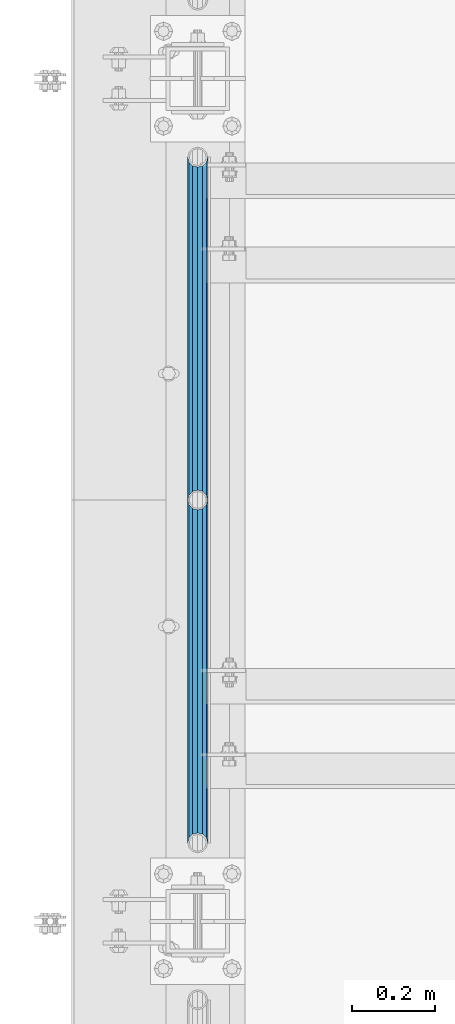
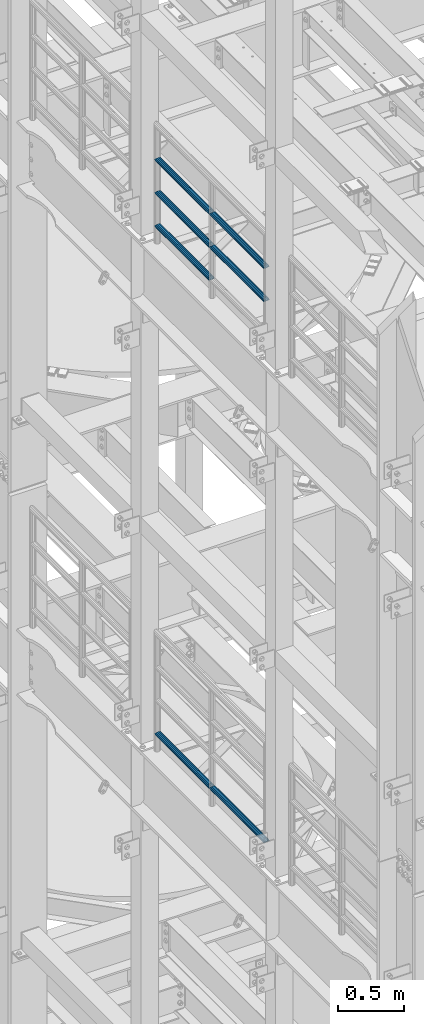
# One storey, part 1251 of 1876: 7 beams, 2 elements without a shape of their own.
"""IFC2X3 building model written with IfcOpenShell, lengths in millimetres."""

from ifc_helpers import new_model, si_unit, frame, origin_with_axes, place, context, subcontext, project, spatial, faceted_brep, material, type_object, element, aggregate, save


model = new_model("IFC2X3")

# Units and contexts
model_context = context("Model", 3, precision=1e-05, world=origin_with_axes())
body_context = subcontext(model_context, "Body", "Model", "MODEL_VIEW")
ifc_project = project(units=[si_unit("LENGTHUNIT", "METRE", prefix="MILLI"), si_unit("AREAUNIT", "SQUARE_METRE"), si_unit("VOLUMEUNIT", "CUBIC_METRE"), si_unit("MASSUNIT", "GRAM", prefix="KILO"), si_unit("TIMEUNIT", "SECOND"), si_unit("PLANEANGLEUNIT", "RADIAN"), si_unit("SOLIDANGLEUNIT", "STERADIAN"), si_unit("THERMODYNAMICTEMPERATUREUNIT", "DEGREE_CELSIUS"), si_unit("LUMINOUSINTENSITYUNIT", "LUMEN")], contexts=[model_context])

# Site, building, storey
site_placement = place(None, origin_with_axes())
site = spatial("IfcSite", under=ifc_project, at=site_placement, CompositionType="ELEMENT")
building_placement = place(site_placement, origin_with_axes())
building = spatial("IfcBuilding", under=site, at=building_placement, Name="Undefined", CompositionType="ELEMENT")
storey_placement = place(building_placement, origin_with_axes())
storey = spatial("IfcBuildingStorey", under=building, at=storey_placement, Name="Undefined", CompositionType="ELEMENT", Elevation=0.0)

# Assembly, beams
assembly_1_placement = place(storey_placement, origin_with_axes())
assembly_1 = element("IfcElementAssembly", 1, at=assembly_1_placement, inside=storey, Name="RAIL", AssemblyPlace="NOTDEFINED", PredefinedType="RIGID_FRAME")
ifc_material = material()
beam_type = type_object("IfcBeamType", Name="PIPE1-1/2SCH40", PredefinedType="NOTDEFINED")
beam_1_placement = place(assembly_1_placement, frame((-1.81898940354586e-12, 5398.77, 18145.125), z_axis=(0.0, 0.0, 1.0), x_axis=(0.0, -1.0, 0.0)))
beam_1 = element("IfcBeam", 2, at=beam_1_placement, type_object=beam_type, material=ifc_material, Name="RAIL", ObjectType="PIPE1-1/2SCH40", context=body_context, shape_type="Brep", body=[
    faceted_brep([(805.872807006681, -12.0649999999996, 20.8971929933177), (805.872807006683, -12.0649999999996, 15.8661214311796), (805.379378568819, -10.2235000000001, 17.7076214311819), (802.640000000001, 0.0, 20.4470000000001), (802.640000000001, 0.0, 24.130000000001), (805.379378568819, 10.2235000000001, 17.7076214311819), (805.872807006683, 12.0649999999996, 15.8661214311796), (805.872807006681, 12.0649999999996, 20.8971929933177), (826.77, 24.1300000000001, 0.0), (814.705, 20.8971929933186, 12.0649999999987), (814.705, 20.8971929933186, -12.0649999999987), (811.515428437862, 17.7076214311801, 10.2235000000001), (814.254807006682, 20.4470000000001, 0.0), (811.515428437862, 17.7076214311801, -10.2235000000001), (805.872807006683, 12.0649999999996, -15.8661214311796), (805.872807006681, 12.0649999999996, -20.8971929933177), (805.379378568819, 10.2235000000001, -17.7076214311819), (802.640000000001, 0.0, -20.4470000000001), (802.640000000001, 0.0, -24.130000000001), (805.872807006683, -12.0649999999996, -15.8661214311796), (805.872807006681, -12.0649999999996, -20.8971929933177), (805.379378568819, -10.2235000000001, -17.7076214311819), (826.77, -24.1300000000001, 0.0), (814.705, -20.8971929933186, -12.0649999999987), (814.705, -20.8971929933186, 12.0649999999987), (811.515428437862, -17.7076214311801, -10.2235000000001), (814.254807006682, -20.4470000000001, 0.0), (811.515428437862, -17.7076214311801, 10.2235000000001), (12.0650000000064, -20.8971929933177, -12.0649999999987), (20.8971929933249, -12.0650000000005, -20.8971929933177), (0.0, 24.1299999999992, 0.0), (12.0650000000064, 20.8971929933177, -12.0649999999987), (12.0650000000064, 20.8971929933177, 12.0649999999987), (20.8971929933249, 12.0650000000005, 20.8971929933177), (24.1300000000064, 0.0, 24.130000000001), (20.8971929933249, 12.0650000000005, -20.8971929933177), (24.1300000000063, 0.0, -24.130000000001), (24.1300000000063, 0.0, -20.4470000000001), (20.8971929933249, -12.0650000000005, -15.8661214311796), (21.3906214311868, -10.2235000000001, -17.7076214311819), (21.3906214311868, 10.2235000000001, -17.7076214311819), (20.8971929933249, 12.0650000000005, -15.8661214311796), (15.2545715621445, 17.7076214311801, -10.2235000000001), (12.5151929933249, 20.4470000000001, 0.0), (15.2545715621445, 17.7076214311801, 10.2235000000001), (20.8971929933249, 12.0650000000005, 15.8661214311796), (21.3906214311868, 10.2235000000001, 17.7076214311819), (24.1300000000064, 0.0, 20.4470000000001), (21.3906214311868, -10.2235000000001, 17.7076214311819), (20.8971929933249, -12.0650000000005, 15.8661214311796), (20.8971929933249, -12.0650000000005, 20.8971929933177), (12.0650000000064, -20.8971929933177, 12.0649999999987), (0.0, -24.1299999999992, 0.0), (15.2545715621445, -17.7076214311801, 10.2235000000001), (12.5151929933249, -20.4470000000001, 0.0), (15.2545715621445, -17.7076214311801, -10.2235000000001)], [[[0, 1, 2, 3, 4]], [[4, 3, 5, 6, 7]], [[8, 9, 10]], [[7, 6, 11, 12, 13, 14, 15, 10, 9]], [[16, 17, 18, 15, 14]], [[19, 20, 18, 17, 21]], [[22, 23, 24]], [[24, 23, 20, 19, 25, 26, 27, 1, 0]], [[28, 29, 20, 23]], [[30, 31, 32]], [[33, 34, 4, 7]], [[32, 33, 7, 9]], [[30, 32, 9, 8]], [[31, 30, 8, 10]], [[35, 31, 10, 15]], [[36, 35, 15, 18]], [[29, 36, 18, 20]], [[37, 36, 29, 38, 39]], [[40, 41, 35, 36, 37]], [[32, 31, 35, 41, 42, 43, 44, 45, 33]], [[33, 45, 46, 47, 34]], [[34, 47, 48, 49, 50]], [[34, 50, 0, 4]], [[50, 51, 24, 0]], [[51, 52, 22, 24]], [[52, 28, 23, 22]], [[51, 28, 52]], [[50, 49, 53, 54, 55, 38, 29, 28, 51]], [[55, 54, 26, 25]], [[21, 39, 38, 55, 25, 19]], [[37, 39, 21, 17]], [[40, 37, 17, 16]], [[42, 41, 40, 16, 14, 13]], [[43, 42, 13, 12]], [[44, 43, 12, 11]], [[5, 46, 45, 44, 11, 6]], [[47, 46, 5, 3]], [[48, 47, 3, 2]], [[53, 49, 48, 2, 1, 27]], [[54, 53, 27, 26]]]),
])
beam_2_placement = place(assembly_1_placement, frame((-1.81898940354586e-12, 3745.23, 18449.925), z_axis=(0.0, 0.0, -1.0), x_axis=(0.0, 1.0, 0.0)))
beam_2 = element("IfcBeam", 3, at=beam_2_placement, type_object=beam_type, material=ifc_material, Name="RAIL", ObjectType="PIPE1-1/2SCH40", context=body_context, shape_type="Brep", body=[
    faceted_brep([(0.0, 24.1299999999992, 0.0), (12.0650000000064, 20.8971929933177, -12.0649999999987), (12.0650000000064, 20.8971929933177, 12.0649999999987), (12.0650000000064, -20.8971929933177, 12.0649999999987), (12.0650000000064, -20.8971929933177, -12.0649999999987), (0.0, -24.1299999999992, 0.0), (20.8971929933249, -12.0650000000005, 20.8971929933177), (20.8971929933249, -12.0650000000005, 15.8661214311796), (15.2545715621445, -17.7076214311801, 10.2235000000001), (12.5151929933249, -20.4470000000001, 0.0), (15.2545715621445, -17.7076214311801, -10.2235000000001), (20.8971929933249, -12.0650000000005, -15.8661214311796), (20.8971929933249, -12.0650000000005, -20.8971929933177), (24.1300000000063, 0.0, -20.4470000000001), (24.1300000000063, 0.0, -24.130000000001), (21.3906214311868, -10.2235000000001, -17.7076214311819), (21.3906214311868, 10.2235000000001, -17.7076214311819), (20.8971929933249, 12.0650000000005, -15.8661214311796), (20.8971929933249, 12.0650000000005, -20.8971929933177), (15.2545715621445, 17.7076214311801, -10.2235000000001), (12.5151929933249, 20.4470000000001, 0.0), (15.2545715621445, 17.7076214311801, 10.2235000000001), (20.8971929933249, 12.0650000000005, 15.8661214311796), (20.8971929933249, 12.0650000000005, 20.8971929933177), (21.3906214311868, 10.2235000000001, 17.7076214311819), (24.1300000000064, 0.0, 20.4470000000001), (24.1300000000064, 0.0, 24.130000000001), (21.3906214311868, -10.2235000000001, 17.7076214311819), (826.77, 24.1300000000001, 0.0), (814.705, 20.8971929933186, -12.0649999999987), (805.872807006681, 12.0649999999996, -20.8971929933177), (826.77, -24.1300000000001, 0.0), (814.705, -20.8971929933186, -12.0649999999987), (814.705, -20.8971929933186, 12.0649999999987), (805.872807006681, -12.0649999999996, 20.8971929933177), (805.872807006681, -12.0649999999996, -20.8971929933177), (802.640000000001, 0.0, -24.130000000001), (805.379378568819, 10.2235000000001, -17.7076214311819), (802.640000000001, 0.0, -20.4470000000001), (805.872807006683, 12.0649999999996, -15.8661214311796), (805.872807006683, -12.0649999999996, -15.8661214311796), (805.379378568819, -10.2235000000001, -17.7076214311819), (811.515428437862, -17.7076214311801, -10.2235000000001), (814.254807006682, -20.4470000000001, 0.0), (811.515428437862, -17.7076214311801, 10.2235000000001), (805.872807006683, -12.0649999999996, 15.8661214311796), (805.379378568819, -10.2235000000001, 17.7076214311819), (802.640000000001, 0.0, 20.4470000000001), (802.640000000001, 0.0, 24.130000000001), (805.872807006681, 12.0649999999996, 20.8971929933177), (814.705, 20.8971929933186, 12.0649999999987), (805.872807006683, 12.0649999999996, 15.8661214311796), (811.515428437862, 17.7076214311801, 10.2235000000001), (814.254807006682, 20.4470000000001, 0.0), (811.515428437862, 17.7076214311801, -10.2235000000001), (805.379378568819, 10.2235000000001, 17.7076214311819)], [[[0, 1, 2]], [[3, 4, 5]], [[6, 7, 8, 9, 10, 11, 12, 4, 3]], [[13, 14, 12, 11, 15]], [[16, 17, 18, 14, 13]], [[2, 1, 18, 17, 19, 20, 21, 22, 23]], [[23, 22, 24, 25, 26]], [[26, 25, 27, 7, 6]], [[1, 0, 28, 29]], [[18, 1, 29, 30]], [[31, 32, 33]], [[6, 3, 33, 34]], [[3, 5, 31, 33]], [[5, 4, 32, 31]], [[4, 12, 35, 32]], [[12, 14, 36, 35]], [[14, 18, 30, 36]], [[37, 38, 36, 30, 39]], [[40, 35, 36, 38, 41]], [[33, 32, 35, 40, 42, 43, 44, 45, 34]], [[34, 45, 46, 47, 48]], [[26, 6, 34, 48]], [[2, 23, 49, 50]], [[23, 26, 48, 49]], [[0, 2, 50, 28]], [[28, 50, 29]], [[49, 51, 52, 53, 54, 39, 30, 29, 50]], [[48, 47, 55, 51, 49]], [[25, 24, 55, 47]], [[55, 24, 22, 21, 52, 51]], [[21, 20, 53, 52]], [[20, 19, 54, 53]], [[19, 17, 16, 37, 39, 54]], [[16, 13, 38, 37]], [[13, 15, 41, 38]], [[41, 15, 11, 10, 42, 40]], [[10, 9, 43, 42]], [[9, 8, 44, 43]], [[8, 7, 27, 46, 45, 44]], [[27, 25, 47, 46]]]),
])
beam_3_placement = place(assembly_1_placement, frame((-1.81898940354586e-12, 4572.0, 18449.925), z_axis=(0.0, 0.0, -1.0), x_axis=(0.0, 1.0, 0.0)))
beam_3 = element("IfcBeam", 4, at=beam_3_placement, type_object=beam_type, material=ifc_material, Name="RAIL", ObjectType="PIPE1-1/2SCH40", context=body_context, shape_type="Brep", body=[
    faceted_brep([(0.0, 24.1299999999992, 0.0), (12.0650000000064, 20.8971929933177, -12.0649999999987), (12.0650000000064, 20.8971929933177, 12.0649999999987), (12.0650000000064, -20.8971929933177, 12.0649999999987), (12.0650000000064, -20.8971929933177, -12.0649999999987), (0.0, -24.1299999999992, 0.0), (20.8971929933249, -12.0650000000005, 20.8971929933177), (20.8971929933249, -12.0650000000005, 15.8661214311796), (15.2545715621445, -17.7076214311801, 10.2235000000001), (12.5151929933249, -20.4470000000001, 0.0), (15.2545715621445, -17.7076214311801, -10.2235000000001), (20.8971929933249, -12.0650000000005, -15.8661214311796), (20.8971929933249, -12.0650000000005, -20.8971929933177), (24.1300000000063, 0.0, -20.4470000000001), (24.1300000000063, 0.0, -24.130000000001), (21.3906214311868, -10.2235000000001, -17.7076214311819), (21.3906214311868, 10.2235000000001, -17.7076214311819), (20.8971929933249, 12.0650000000005, -15.8661214311796), (20.8971929933249, 12.0650000000005, -20.8971929933177), (15.2545715621445, 17.7076214311801, -10.2235000000001), (12.5151929933249, 20.4470000000001, 0.0), (15.2545715621445, 17.7076214311801, 10.2235000000001), (20.8971929933249, 12.0650000000005, 15.8661214311796), (20.8971929933249, 12.0650000000005, 20.8971929933177), (21.3906214311868, 10.2235000000001, 17.7076214311819), (24.1300000000064, 0.0, 20.4470000000001), (24.1300000000064, 0.0, 24.130000000001), (21.3906214311868, -10.2235000000001, 17.7076214311819), (826.77, 24.1300000000001, 0.0), (814.705, 20.8971929933186, -12.0649999999987), (805.872807006681, 12.0649999999996, -20.8971929933177), (826.77, -24.1300000000001, 0.0), (814.705, -20.8971929933186, -12.0649999999987), (814.705, -20.8971929933186, 12.0649999999987), (805.872807006681, -12.0649999999996, 20.8971929933177), (805.872807006681, -12.0649999999996, -20.8971929933177), (802.640000000001, 0.0, -24.130000000001), (805.379378568819, 10.2235000000001, -17.7076214311819), (802.640000000001, 0.0, -20.4470000000001), (805.872807006683, 12.0649999999996, -15.8661214311796), (805.872807006683, -12.0649999999996, -15.8661214311796), (805.379378568819, -10.2235000000001, -17.7076214311819), (811.515428437862, -17.7076214311801, -10.2235000000001), (814.254807006682, -20.4470000000001, 0.0), (811.515428437862, -17.7076214311801, 10.2235000000001), (805.872807006683, -12.0649999999996, 15.8661214311796), (805.379378568819, -10.2235000000001, 17.7076214311819), (802.640000000001, 0.0, 20.4470000000001), (802.640000000001, 0.0, 24.130000000001), (805.872807006681, 12.0649999999996, 20.8971929933177), (814.705, 20.8971929933186, 12.0649999999987), (805.872807006683, 12.0649999999996, 15.8661214311796), (811.515428437862, 17.7076214311801, 10.2235000000001), (814.254807006682, 20.4470000000001, 0.0), (811.515428437862, 17.7076214311801, -10.2235000000001), (805.379378568819, 10.2235000000001, 17.7076214311819)], [[[0, 1, 2]], [[3, 4, 5]], [[6, 7, 8, 9, 10, 11, 12, 4, 3]], [[13, 14, 12, 11, 15]], [[16, 17, 18, 14, 13]], [[2, 1, 18, 17, 19, 20, 21, 22, 23]], [[23, 22, 24, 25, 26]], [[26, 25, 27, 7, 6]], [[1, 0, 28, 29]], [[18, 1, 29, 30]], [[31, 32, 33]], [[6, 3, 33, 34]], [[3, 5, 31, 33]], [[5, 4, 32, 31]], [[4, 12, 35, 32]], [[12, 14, 36, 35]], [[14, 18, 30, 36]], [[37, 38, 36, 30, 39]], [[40, 35, 36, 38, 41]], [[33, 32, 35, 40, 42, 43, 44, 45, 34]], [[34, 45, 46, 47, 48]], [[26, 6, 34, 48]], [[2, 23, 49, 50]], [[23, 26, 48, 49]], [[0, 2, 50, 28]], [[28, 50, 29]], [[49, 51, 52, 53, 54, 39, 30, 29, 50]], [[48, 47, 55, 51, 49]], [[25, 24, 55, 47]], [[55, 24, 22, 21, 52, 51]], [[21, 20, 53, 52]], [[20, 19, 54, 53]], [[19, 17, 16, 37, 39, 54]], [[16, 13, 38, 37]], [[13, 15, 41, 38]], [[41, 15, 11, 10, 42, 40]], [[10, 9, 43, 42]], [[9, 8, 44, 43]], [[8, 7, 27, 46, 45, 44]], [[27, 25, 47, 46]]]),
])
beam_4_placement = place(assembly_1_placement, frame((-1.81898940354586e-12, 3745.23, 18754.725), z_axis=(0.0, 0.0, -1.0), x_axis=(0.0, 1.0, 0.0)))
beam_4 = element("IfcBeam", 5, at=beam_4_placement, type_object=beam_type, material=ifc_material, Name="RAIL", ObjectType="PIPE1-1/2SCH40", context=body_context, shape_type="Brep", body=[
    faceted_brep([(0.0, 24.1299999999992, 0.0), (12.0650000000064, 20.8971929933177, -12.0649999999987), (12.0650000000064, 20.8971929933177, 12.0649999999987), (12.0650000000064, -20.8971929933177, 12.0649999999987), (12.0650000000064, -20.8971929933177, -12.0649999999987), (0.0, -24.1299999999992, 0.0), (20.8971929933249, -12.0650000000005, 20.8971929933177), (20.8971929933249, -12.0650000000005, 15.8661214311796), (15.2545715621445, -17.7076214311801, 10.2235000000001), (12.5151929933249, -20.4470000000001, 0.0), (15.2545715621445, -17.7076214311801, -10.2235000000001), (20.8971929933249, -12.0650000000005, -15.8661214311796), (20.8971929933249, -12.0650000000005, -20.8971929933177), (24.1300000000063, 0.0, -20.4470000000001), (24.1300000000063, 0.0, -24.130000000001), (21.3906214311868, -10.2235000000001, -17.7076214311819), (21.3906214311868, 10.2235000000001, -17.7076214311819), (20.8971929933249, 12.0650000000005, -15.8661214311796), (20.8971929933249, 12.0650000000005, -20.8971929933177), (15.2545715621445, 17.7076214311801, -10.2235000000001), (12.5151929933249, 20.4470000000001, 0.0), (15.2545715621445, 17.7076214311801, 10.2235000000001), (20.8971929933249, 12.0650000000005, 15.8661214311796), (20.8971929933249, 12.0650000000005, 20.8971929933177), (21.3906214311868, 10.2235000000001, 17.7076214311819), (24.1300000000064, 0.0, 20.4470000000001), (24.1300000000064, 0.0, 24.130000000001), (21.3906214311868, -10.2235000000001, 17.7076214311819), (826.77, 24.1300000000001, 0.0), (814.705, 20.8971929933186, -12.0649999999987), (805.872807006681, 12.0649999999996, -20.8971929933177), (826.77, -24.1300000000001, 0.0), (814.705, -20.8971929933186, -12.0649999999987), (814.705, -20.8971929933186, 12.0649999999987), (805.872807006681, -12.0649999999996, 20.8971929933177), (805.872807006681, -12.0649999999996, -20.8971929933177), (802.640000000001, 0.0, -24.130000000001), (805.379378568819, 10.2235000000001, -17.7076214311819), (802.640000000001, 0.0, -20.4470000000001), (805.872807006683, 12.0649999999996, -15.8661214311796), (805.872807006683, -12.0649999999996, -15.8661214311796), (805.379378568819, -10.2235000000001, -17.7076214311819), (811.515428437862, -17.7076214311801, -10.2235000000001), (814.254807006682, -20.4470000000001, 0.0), (811.515428437862, -17.7076214311801, 10.2235000000001), (805.872807006683, -12.0649999999996, 15.8661214311796), (805.379378568819, -10.2235000000001, 17.7076214311819), (802.640000000001, 0.0, 20.4470000000001), (802.640000000001, 0.0, 24.130000000001), (805.872807006681, 12.0649999999996, 20.8971929933177), (814.705, 20.8971929933186, 12.0649999999987), (805.872807006683, 12.0649999999996, 15.8661214311796), (811.515428437862, 17.7076214311801, 10.2235000000001), (814.254807006682, 20.4470000000001, 0.0), (811.515428437862, 17.7076214311801, -10.2235000000001), (805.379378568819, 10.2235000000001, 17.7076214311819)], [[[0, 1, 2]], [[3, 4, 5]], [[6, 7, 8, 9, 10, 11, 12, 4, 3]], [[13, 14, 12, 11, 15]], [[16, 17, 18, 14, 13]], [[2, 1, 18, 17, 19, 20, 21, 22, 23]], [[23, 22, 24, 25, 26]], [[26, 25, 27, 7, 6]], [[1, 0, 28, 29]], [[18, 1, 29, 30]], [[31, 32, 33]], [[6, 3, 33, 34]], [[3, 5, 31, 33]], [[5, 4, 32, 31]], [[4, 12, 35, 32]], [[12, 14, 36, 35]], [[14, 18, 30, 36]], [[37, 38, 36, 30, 39]], [[40, 35, 36, 38, 41]], [[33, 32, 35, 40, 42, 43, 44, 45, 34]], [[34, 45, 46, 47, 48]], [[26, 6, 34, 48]], [[2, 23, 49, 50]], [[23, 26, 48, 49]], [[0, 2, 50, 28]], [[28, 50, 29]], [[49, 51, 52, 53, 54, 39, 30, 29, 50]], [[48, 47, 55, 51, 49]], [[25, 24, 55, 47]], [[55, 24, 22, 21, 52, 51]], [[21, 20, 53, 52]], [[20, 19, 54, 53]], [[19, 17, 16, 37, 39, 54]], [[16, 13, 38, 37]], [[13, 15, 41, 38]], [[41, 15, 11, 10, 42, 40]], [[10, 9, 43, 42]], [[9, 8, 44, 43]], [[8, 7, 27, 46, 45, 44]], [[27, 25, 47, 46]]]),
])
beam_5_placement = place(assembly_1_placement, frame((-1.81898940354586e-12, 4572.0, 18754.725), z_axis=(0.0, 0.0, -1.0), x_axis=(0.0, 1.0, 0.0)))
beam_5 = element("IfcBeam", 6, at=beam_5_placement, type_object=beam_type, material=ifc_material, Name="RAIL", ObjectType="PIPE1-1/2SCH40", context=body_context, shape_type="Brep", body=[
    faceted_brep([(0.0, 24.1299999999992, 0.0), (12.0650000000064, 20.8971929933177, -12.0649999999987), (12.0650000000064, 20.8971929933177, 12.0649999999987), (12.0650000000064, -20.8971929933177, 12.0649999999987), (12.0650000000064, -20.8971929933177, -12.0649999999987), (0.0, -24.1299999999992, 0.0), (20.8971929933249, -12.0650000000005, 20.8971929933177), (20.8971929933249, -12.0650000000005, 15.8661214311796), (15.2545715621445, -17.7076214311801, 10.2235000000001), (12.5151929933249, -20.4470000000001, 0.0), (15.2545715621445, -17.7076214311801, -10.2235000000001), (20.8971929933249, -12.0650000000005, -15.8661214311796), (20.8971929933249, -12.0650000000005, -20.8971929933177), (24.1300000000063, 0.0, -20.4470000000001), (24.1300000000063, 0.0, -24.130000000001), (21.3906214311868, -10.2235000000001, -17.7076214311819), (21.3906214311868, 10.2235000000001, -17.7076214311819), (20.8971929933249, 12.0650000000005, -15.8661214311796), (20.8971929933249, 12.0650000000005, -20.8971929933177), (15.2545715621445, 17.7076214311801, -10.2235000000001), (12.5151929933249, 20.4470000000001, 0.0), (15.2545715621445, 17.7076214311801, 10.2235000000001), (20.8971929933249, 12.0650000000005, 15.8661214311796), (20.8971929933249, 12.0650000000005, 20.8971929933177), (21.3906214311868, 10.2235000000001, 17.7076214311819), (24.1300000000064, 0.0, 20.4470000000001), (24.1300000000064, 0.0, 24.130000000001), (21.3906214311868, -10.2235000000001, 17.7076214311819), (826.77, 24.1300000000001, 0.0), (814.705, 20.8971929933186, -12.0649999999987), (805.872807006681, 12.0649999999996, -20.8971929933177), (826.77, -24.1300000000001, 0.0), (814.705, -20.8971929933186, -12.0649999999987), (814.705, -20.8971929933186, 12.0649999999987), (805.872807006681, -12.0649999999996, 20.8971929933177), (805.872807006681, -12.0649999999996, -20.8971929933177), (802.640000000001, 0.0, -24.130000000001), (805.379378568819, 10.2235000000001, -17.7076214311819), (802.640000000001, 0.0, -20.4470000000001), (805.872807006683, 12.0649999999996, -15.8661214311796), (805.872807006683, -12.0649999999996, -15.8661214311796), (805.379378568819, -10.2235000000001, -17.7076214311819), (811.515428437862, -17.7076214311801, -10.2235000000001), (814.254807006682, -20.4470000000001, 0.0), (811.515428437862, -17.7076214311801, 10.2235000000001), (805.872807006683, -12.0649999999996, 15.8661214311796), (805.379378568819, -10.2235000000001, 17.7076214311819), (802.640000000001, 0.0, 20.4470000000001), (802.640000000001, 0.0, 24.130000000001), (805.872807006681, 12.0649999999996, 20.8971929933177), (814.705, 20.8971929933186, 12.0649999999987), (805.872807006683, 12.0649999999996, 15.8661214311796), (811.515428437862, 17.7076214311801, 10.2235000000001), (814.254807006682, 20.4470000000001, 0.0), (811.515428437862, 17.7076214311801, -10.2235000000001), (805.379378568819, 10.2235000000001, 17.7076214311819)], [[[0, 1, 2]], [[3, 4, 5]], [[6, 7, 8, 9, 10, 11, 12, 4, 3]], [[13, 14, 12, 11, 15]], [[16, 17, 18, 14, 13]], [[2, 1, 18, 17, 19, 20, 21, 22, 23]], [[23, 22, 24, 25, 26]], [[26, 25, 27, 7, 6]], [[1, 0, 28, 29]], [[18, 1, 29, 30]], [[31, 32, 33]], [[6, 3, 33, 34]], [[3, 5, 31, 33]], [[5, 4, 32, 31]], [[4, 12, 35, 32]], [[12, 14, 36, 35]], [[14, 18, 30, 36]], [[37, 38, 36, 30, 39]], [[40, 35, 36, 38, 41]], [[33, 32, 35, 40, 42, 43, 44, 45, 34]], [[34, 45, 46, 47, 48]], [[26, 6, 34, 48]], [[2, 23, 49, 50]], [[23, 26, 48, 49]], [[0, 2, 50, 28]], [[28, 50, 29]], [[49, 51, 52, 53, 54, 39, 30, 29, 50]], [[48, 47, 55, 51, 49]], [[25, 24, 55, 47]], [[55, 24, 22, 21, 52, 51]], [[21, 20, 53, 52]], [[20, 19, 54, 53]], [[19, 17, 16, 37, 39, 54]], [[16, 13, 38, 37]], [[13, 15, 41, 38]], [[41, 15, 11, 10, 42, 40]], [[10, 9, 43, 42]], [[9, 8, 44, 43]], [[8, 7, 27, 46, 45, 44]], [[27, 25, 47, 46]]]),
])
aggregate(assembly_1, [beam_1, beam_2, beam_3, beam_4, beam_5])

assembly_2_placement = place(storey_placement, origin_with_axes())
assembly_2 = element("IfcElementAssembly", 7, at=assembly_2_placement, inside=storey, Name="RAIL", AssemblyPlace="NOTDEFINED", PredefinedType="RIGID_FRAME")
beam_6_placement = place(assembly_2_placement, frame((-1.81898940354586e-12, 4572.0, 13471.525), z_axis=(0.0, 0.0, 1.0), x_axis=(0.0, -1.0, 0.0)))
beam_6 = element("IfcBeam", 8, at=beam_6_placement, type_object=beam_type, material=ifc_material, Name="RAIL", ObjectType="PIPE1-1/2SCH40", context=body_context, shape_type="Brep", body=[
    faceted_brep([(805.872807006681, -12.0649999999996, 20.8971929933177), (805.872807006683, -12.0649999999996, 15.8661214311796), (805.379378568819, -10.2235000000001, 17.7076214311819), (802.640000000001, 0.0, 20.4470000000001), (802.640000000001, 0.0, 24.130000000001), (805.379378568819, 10.2235000000001, 17.7076214311819), (805.872807006683, 12.0649999999996, 15.8661214311796), (805.872807006681, 12.0649999999996, 20.8971929933177), (826.77, 24.1300000000001, 0.0), (814.705, 20.8971929933186, 12.0649999999987), (814.705, 20.8971929933186, -12.0649999999987), (811.515428437862, 17.7076214311801, 10.2235000000001), (814.254807006682, 20.4470000000001, 0.0), (811.515428437862, 17.7076214311801, -10.2235000000001), (805.872807006683, 12.0649999999996, -15.8661214311796), (805.872807006681, 12.0649999999996, -20.8971929933177), (805.379378568819, 10.2235000000001, -17.7076214311819), (802.640000000001, 0.0, -20.4470000000001), (802.640000000001, 0.0, -24.130000000001), (805.872807006683, -12.0649999999996, -15.8661214311796), (805.872807006681, -12.0649999999996, -20.8971929933177), (805.379378568819, -10.2235000000001, -17.7076214311819), (826.77, -24.1300000000001, 0.0), (814.705, -20.8971929933186, -12.0649999999987), (814.705, -20.8971929933186, 12.0649999999987), (811.515428437862, -17.7076214311801, -10.2235000000001), (814.254807006682, -20.4470000000001, 0.0), (811.515428437862, -17.7076214311801, 10.2235000000001), (12.0650000000064, -20.8971929933177, -12.0649999999987), (20.8971929933249, -12.0650000000005, -20.8971929933177), (0.0, 24.1299999999992, 0.0), (12.0650000000064, 20.8971929933177, -12.0649999999987), (12.0650000000064, 20.8971929933177, 12.0649999999987), (20.8971929933249, 12.0650000000005, 20.8971929933177), (24.1300000000064, 0.0, 24.130000000001), (20.8971929933249, 12.0650000000005, -20.8971929933177), (24.1300000000063, 0.0, -24.130000000001), (24.1300000000063, 0.0, -20.4470000000001), (20.8971929933249, -12.0650000000005, -15.8661214311796), (21.3906214311868, -10.2235000000001, -17.7076214311819), (21.3906214311868, 10.2235000000001, -17.7076214311819), (20.8971929933249, 12.0650000000005, -15.8661214311796), (15.2545715621445, 17.7076214311801, -10.2235000000001), (12.5151929933249, 20.4470000000001, 0.0), (15.2545715621445, 17.7076214311801, 10.2235000000001), (20.8971929933249, 12.0650000000005, 15.8661214311796), (21.3906214311868, 10.2235000000001, 17.7076214311819), (24.1300000000064, 0.0, 20.4470000000001), (21.3906214311868, -10.2235000000001, 17.7076214311819), (20.8971929933249, -12.0650000000005, 15.8661214311796), (20.8971929933249, -12.0650000000005, 20.8971929933177), (12.0650000000064, -20.8971929933177, 12.0649999999987), (0.0, -24.1299999999992, 0.0), (15.2545715621445, -17.7076214311801, 10.2235000000001), (12.5151929933249, -20.4470000000001, 0.0), (15.2545715621445, -17.7076214311801, -10.2235000000001)], [[[0, 1, 2, 3, 4]], [[4, 3, 5, 6, 7]], [[8, 9, 10]], [[7, 6, 11, 12, 13, 14, 15, 10, 9]], [[16, 17, 18, 15, 14]], [[19, 20, 18, 17, 21]], [[22, 23, 24]], [[24, 23, 20, 19, 25, 26, 27, 1, 0]], [[28, 29, 20, 23]], [[30, 31, 32]], [[33, 34, 4, 7]], [[32, 33, 7, 9]], [[30, 32, 9, 8]], [[31, 30, 8, 10]], [[35, 31, 10, 15]], [[36, 35, 15, 18]], [[29, 36, 18, 20]], [[37, 36, 29, 38, 39]], [[40, 41, 35, 36, 37]], [[32, 31, 35, 41, 42, 43, 44, 45, 33]], [[33, 45, 46, 47, 34]], [[34, 47, 48, 49, 50]], [[34, 50, 0, 4]], [[50, 51, 24, 0]], [[51, 52, 22, 24]], [[52, 28, 23, 22]], [[51, 28, 52]], [[50, 49, 53, 54, 55, 38, 29, 28, 51]], [[55, 54, 26, 25]], [[21, 39, 38, 55, 25, 19]], [[37, 39, 21, 17]], [[40, 37, 17, 16]], [[42, 41, 40, 16, 14, 13]], [[43, 42, 13, 12]], [[44, 43, 12, 11]], [[5, 46, 45, 44, 11, 6]], [[47, 46, 5, 3]], [[48, 47, 3, 2]], [[53, 49, 48, 2, 1, 27]], [[54, 53, 27, 26]]]),
])
beam_7_placement = place(assembly_2_placement, frame((-1.81898940354586e-12, 5398.77, 13471.525), z_axis=(0.0, 0.0, 1.0), x_axis=(0.0, -1.0, 0.0)))
beam_7 = element("IfcBeam", 9, at=beam_7_placement, type_object=beam_type, material=ifc_material, Name="RAIL", ObjectType="PIPE1-1/2SCH40", context=body_context, shape_type="Brep", body=[
    faceted_brep([(805.872807006681, -12.0649999999996, 20.8971929933177), (805.872807006683, -12.0649999999996, 15.8661214311796), (805.379378568819, -10.2235000000001, 17.7076214311819), (802.640000000001, 0.0, 20.4470000000001), (802.640000000001, 0.0, 24.130000000001), (805.379378568819, 10.2235000000001, 17.7076214311819), (805.872807006683, 12.0649999999996, 15.8661214311796), (805.872807006681, 12.0649999999996, 20.8971929933177), (826.77, 24.1300000000001, 0.0), (814.705, 20.8971929933186, 12.0649999999987), (814.705, 20.8971929933186, -12.0649999999987), (811.515428437862, 17.7076214311801, 10.2235000000001), (814.254807006682, 20.4470000000001, 0.0), (811.515428437862, 17.7076214311801, -10.2235000000001), (805.872807006683, 12.0649999999996, -15.8661214311796), (805.872807006681, 12.0649999999996, -20.8971929933177), (805.379378568819, 10.2235000000001, -17.7076214311819), (802.640000000001, 0.0, -20.4470000000001), (802.640000000001, 0.0, -24.130000000001), (805.872807006683, -12.0649999999996, -15.8661214311796), (805.872807006681, -12.0649999999996, -20.8971929933177), (805.379378568819, -10.2235000000001, -17.7076214311819), (826.77, -24.1300000000001, 0.0), (814.705, -20.8971929933186, -12.0649999999987), (814.705, -20.8971929933186, 12.0649999999987), (811.515428437862, -17.7076214311801, -10.2235000000001), (814.254807006682, -20.4470000000001, 0.0), (811.515428437862, -17.7076214311801, 10.2235000000001), (12.0650000000064, -20.8971929933177, -12.0649999999987), (20.8971929933249, -12.0650000000005, -20.8971929933177), (0.0, 24.1299999999992, 0.0), (12.0650000000064, 20.8971929933177, -12.0649999999987), (12.0650000000064, 20.8971929933177, 12.0649999999987), (20.8971929933249, 12.0650000000005, 20.8971929933177), (24.1300000000064, 0.0, 24.130000000001), (20.8971929933249, 12.0650000000005, -20.8971929933177), (24.1300000000063, 0.0, -24.130000000001), (24.1300000000063, 0.0, -20.4470000000001), (20.8971929933249, -12.0650000000005, -15.8661214311796), (21.3906214311868, -10.2235000000001, -17.7076214311819), (21.3906214311868, 10.2235000000001, -17.7076214311819), (20.8971929933249, 12.0650000000005, -15.8661214311796), (15.2545715621445, 17.7076214311801, -10.2235000000001), (12.5151929933249, 20.4470000000001, 0.0), (15.2545715621445, 17.7076214311801, 10.2235000000001), (20.8971929933249, 12.0650000000005, 15.8661214311796), (21.3906214311868, 10.2235000000001, 17.7076214311819), (24.1300000000064, 0.0, 20.4470000000001), (21.3906214311868, -10.2235000000001, 17.7076214311819), (20.8971929933249, -12.0650000000005, 15.8661214311796), (20.8971929933249, -12.0650000000005, 20.8971929933177), (12.0650000000064, -20.8971929933177, 12.0649999999987), (0.0, -24.1299999999992, 0.0), (15.2545715621445, -17.7076214311801, 10.2235000000001), (12.5151929933249, -20.4470000000001, 0.0), (15.2545715621445, -17.7076214311801, -10.2235000000001)], [[[0, 1, 2, 3, 4]], [[4, 3, 5, 6, 7]], [[8, 9, 10]], [[7, 6, 11, 12, 13, 14, 15, 10, 9]], [[16, 17, 18, 15, 14]], [[19, 20, 18, 17, 21]], [[22, 23, 24]], [[24, 23, 20, 19, 25, 26, 27, 1, 0]], [[28, 29, 20, 23]], [[30, 31, 32]], [[33, 34, 4, 7]], [[32, 33, 7, 9]], [[30, 32, 9, 8]], [[31, 30, 8, 10]], [[35, 31, 10, 15]], [[36, 35, 15, 18]], [[29, 36, 18, 20]], [[37, 36, 29, 38, 39]], [[40, 41, 35, 36, 37]], [[32, 31, 35, 41, 42, 43, 44, 45, 33]], [[33, 45, 46, 47, 34]], [[34, 47, 48, 49, 50]], [[34, 50, 0, 4]], [[50, 51, 24, 0]], [[51, 52, 22, 24]], [[52, 28, 23, 22]], [[51, 28, 52]], [[50, 49, 53, 54, 55, 38, 29, 28, 51]], [[55, 54, 26, 25]], [[21, 39, 38, 55, 25, 19]], [[37, 39, 21, 17]], [[40, 37, 17, 16]], [[42, 41, 40, 16, 14, 13]], [[43, 42, 13, 12]], [[44, 43, 12, 11]], [[5, 46, 45, 44, 11, 6]], [[47, 46, 5, 3]], [[48, 47, 3, 2]], [[53, 49, 48, 2, 1, 27]], [[54, 53, 27, 26]]]),
])
aggregate(assembly_2, [beam_6, beam_7])

save(model, "model.ifc")
